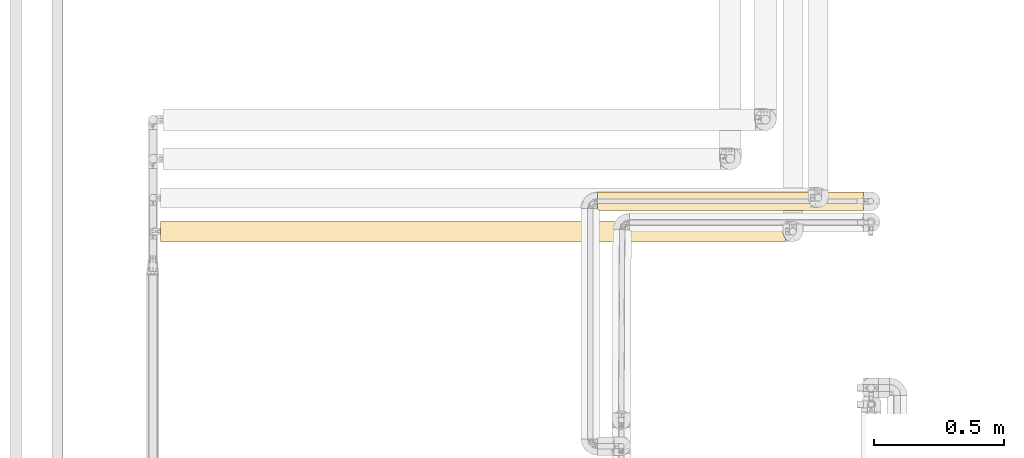
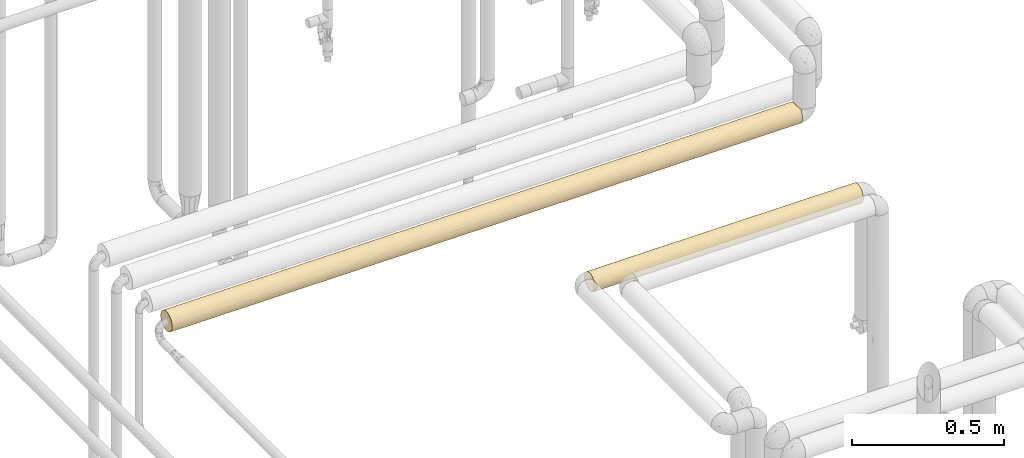
# One storey, part 32 of 827: 2 coverings.
"""IFC2X3 building model written with IfcOpenShell, lengths in millimetres."""

from ifc_helpers import new_model, entity, si_unit, converted_unit, derived_unit, direction, frame, origin, place, context, subcontext, project, spatial, faceted_brep, element, save


model = new_model("IFC2X3")

# Units and contexts
model_context = context("Model", 3, precision=0.01, world=origin(), true_north=direction((6.12303176911189e-17, 1.0)))
body_context = subcontext(model_context, "Body", "Model", "MODEL_VIEW")
ifc_project = project(units=[si_unit("LENGTHUNIT", "METRE", prefix="MILLI"), si_unit("AREAUNIT", "SQUARE_METRE"), si_unit("VOLUMEUNIT", "CUBIC_METRE"), converted_unit("PLANEANGLEUNIT", "DEGREE", entity("IfcRatioMeasure", 0.0174532925199433), si_unit("PLANEANGLEUNIT", "RADIAN"), dimensions=[0, 0, 0, 0, 0, 0, 0]), si_unit("MASSUNIT", "GRAM", prefix="KILO"), derived_unit("MASSDENSITYUNIT", [(si_unit("MASSUNIT", "GRAM", prefix="KILO"), 1), (si_unit("LENGTHUNIT", "METRE"), -3)]), derived_unit("MOMENTOFINERTIAUNIT", [(si_unit("LENGTHUNIT", "METRE"), 4)]), si_unit("TIMEUNIT", "SECOND"), si_unit("FREQUENCYUNIT", "HERTZ"), si_unit("THERMODYNAMICTEMPERATUREUNIT", "DEGREE_CELSIUS"), derived_unit("THERMALTRANSMITTANCEUNIT", [(si_unit("MASSUNIT", "GRAM", prefix="KILO"), 1), (si_unit("THERMODYNAMICTEMPERATUREUNIT", "KELVIN"), -1), (si_unit("TIMEUNIT", "SECOND"), -3)]), derived_unit("VOLUMETRICFLOWRATEUNIT", [(si_unit("LENGTHUNIT", "METRE"), 3), (si_unit("TIMEUNIT", "SECOND"), -1)]), derived_unit("MASSFLOWRATEUNIT", [(si_unit("MASSUNIT", "GRAM", prefix="KILO"), 1), (si_unit("TIMEUNIT", "SECOND"), -1)]), derived_unit("ROTATIONALFREQUENCYUNIT", [(si_unit("TIMEUNIT", "SECOND"), -1)]), si_unit("ELECTRICCURRENTUNIT", "AMPERE"), si_unit("ELECTRICVOLTAGEUNIT", "VOLT"), si_unit("POWERUNIT", "WATT"), si_unit("FORCEUNIT", "NEWTON", prefix="KILO"), si_unit("ILLUMINANCEUNIT", "LUX"), si_unit("LUMINOUSFLUXUNIT", "LUMEN"), si_unit("LUMINOUSINTENSITYUNIT", "CANDELA"), derived_unit("USERDEFINED", [(si_unit("MASSUNIT", "GRAM", prefix="KILO"), -1), (si_unit("LENGTHUNIT", "METRE"), -2), (si_unit("TIMEUNIT", "SECOND"), 3), (si_unit("LUMINOUSFLUXUNIT", "LUMEN"), 1)]), derived_unit("LINEARVELOCITYUNIT", [(si_unit("LENGTHUNIT", "METRE"), 1), (si_unit("TIMEUNIT", "SECOND"), -1)]), si_unit("PRESSUREUNIT", "PASCAL"), derived_unit("USERDEFINED", [(si_unit("LENGTHUNIT", "METRE"), -2), (si_unit("MASSUNIT", "GRAM", prefix="KILO"), 1), (si_unit("TIMEUNIT", "SECOND"), -2)]), derived_unit("LINEARFORCEUNIT", [(si_unit("MASSUNIT", "GRAM", prefix="KILO"), 1), (si_unit("LENGTHUNIT", "METRE"), 1), (si_unit("TIMEUNIT", "SECOND"), -2), (si_unit("LENGTHUNIT", "METRE"), -1)]), derived_unit("PLANARFORCEUNIT", [(si_unit("MASSUNIT", "GRAM", prefix="KILO"), 1), (si_unit("LENGTHUNIT", "METRE"), 1), (si_unit("TIMEUNIT", "SECOND"), -2), (si_unit("LENGTHUNIT", "METRE"), -2)])], contexts=[model_context])

# Site, building, storey
site_placement = place(None, origin())
site = spatial("IfcSite", under=ifc_project, at=site_placement, CompositionType="ELEMENT")
building_placement = place(site_placement, origin())
building = spatial("IfcBuilding", under=site, at=building_placement, CompositionType="ELEMENT")
storey_placement = place(building_placement, frame((0.0, 0.0, 28200.0)))
storey = spatial("IfcBuildingStorey", under=building, at=storey_placement, Name="08", CompositionType="ELEMENT", Elevation=28200.0)

# Coverings
covering_1_placement = place(storey_placement, frame((17833.66, 12899.2, 1862.75)))
element("IfcCovering", 1, at=covering_1_placement, inside=storey, Name=":ADSK_", ObjectType=":ADSK_", PredefinedType="INSULATION", context=body_context, shape_type="Brep", body=[
    faceted_brep([(1022.92, 69.32, 21.68), (1022.92, 71.99, 29.26), (1022.92, 72.9, 37.25), (1022.92, 71.68, 46.47), (1022.92, 68.12, 55.07), (1022.92, 62.45, 62.45), (1022.92, 55.07, 68.12), (1022.92, 46.47, 71.68), (1022.92, 37.25, 72.9), (1022.92, 28.02, 71.68), (1022.92, 19.42, 68.12), (1022.92, 12.04, 62.45), (1022.92, 6.37, 55.07), (1022.92, 2.81, 46.47), (1022.92, 1.6, 37.25), (1022.92, 2.5, 29.26), (1022.92, 5.17, 21.68), (1022.92, 9.47, 14.89), (1022.92, 15.18, 9.25), (1022.92, 59.31, 9.25), (1022.92, 65.02, 14.89), (1.6, 71.68, 28.02), (1.6, 68.12, 19.42), (1.6, 62.45, 12.04), (1.6, 55.07, 6.37), (1.6, 46.47, 2.81), (1.6, 37.25, 1.6), (1.6, 29.11, 2.54), (1.6, 21.41, 5.3), (1.6, 14.55, 9.75), (1.6, 8.88, 15.65), (1.6, 8.88, 58.84), (1.6, 14.55, 64.74), (1.6, 21.41, 69.19), (1.6, 29.11, 71.95), (1.6, 37.25, 72.9), (1.6, 46.47, 71.68), (1.6, 55.07, 68.12), (1.6, 62.45, 62.45), (1.6, 68.12, 55.07), (1.6, 71.68, 46.47), (1.6, 72.9, 37.25), (236.62, 7.3, 17.9), (7.01, 3.47, 25.85), (4.72, 5.76, 20.53), (1017.24, 25.57, 3.56), (1019.64, 20.14, 5.97), (740.67, 22.68, 4.71), (702.55, 30.17, 2.31), (241.25, 2.67, 28.57), (299.95, 37.25, 1.6), (306.19, 25.18, 3.7), (421.06, 4.58, 22.96), (425.84, 1.6, 37.25), (262.39, 1.6, 37.25), (217.36, 1.6, 37.25), (8.41, 2.07, 31.47), (206.28, 19.1, 6.56), (515.9, 2.36, 29.91), (605.96, 1.6, 37.25), (515.9, 1.6, 37.25), (278.89, 13.35, 10.79), (806.79, 37.25, 1.6), (1015.27, 37.25, 1.6), (1015.76, 31.32, 2.09), (476.36, 8.92, 15.59), (510.26, 17.31, 7.69), (627.19, 4.13, 24.05), (732.02, 2.27, 30.34), (668.76, 12.35, 11.73), (694.98, 17.26, 7.73), (210.08, 37.25, 1.6), (471.76, 30.57, 2.22), (418.56, 37.25, 1.6), (598.31, 37.25, 1.6), (712.79, 7.13, 18.17), (8.88, 1.6, 37.25), (814.44, 1.6, 37.25), (827.46, 4.45, 23.26), (511.37, 23.72, 4.26), (769.41, 1.6, 37.25), (281.01, 50.89, 4.31), (244.66, 65.53, 15.54), (234.73, 58.95, 8.96), (507.62, 48.48, 3.41), (605.96, 72.9, 37.25), (454.87, 72.24, 30.42), (303.78, 72.9, 37.25), (519.48, 70.32, 23.93), (314.14, 70.18, 23.6), (735.66, 46.16, 2.73), (1017.24, 48.92, 3.56), (1015.76, 43.17, 2.09), (314.32, 43.79, 2.2), (1019.64, 54.35, 5.97), (774.14, 57.04, 7.59), (604.89, 67.36, 18.17), (710.2, 71.48, 27.31), (717.44, 63.02, 12.61), (814.44, 72.9, 37.25), (242.48, 72.2, 30.23), (512.56, 57.18, 7.69), (489.28, 63.18, 12.78), (829.99, 67.36, 18.17), (418.88, 66.92, 17.49), (239.22, 65.53, 58.95), (310.05, 70.18, 50.89), (786.74, 65.53, 58.95), (528.86, 60.19, 64.53), (601.05, 50.89, 70.18), (747.68, 58.95, 65.53), (714.47, 70.18, 50.89), (512.26, 65.53, 58.95), (251.19, 72.2, 44.23), (460.48, 72.2, 44.26), (710.2, 72.3, 43.74), (310.05, 58.95, 65.53), (774.98, 45.35, 71.96), (314.32, 43.95, 72.26), (418.56, 37.25, 72.9), (537.76, 43.77, 72.29), (512.26, 70.24, 50.75), (817.43, 52.48, 69.48), (210.08, 37.25, 72.9), (243.76, 50.89, 70.18), (720.74, 37.25, 72.9), (195.62, 17.85, 67.16), (261.88, 25.18, 70.79), (749.04, 4.31, 50.89), (535.86, 4.03, 50.19), (642.65, 2.24, 44.0), (569.65, 30.44, 72.24), (498.79, 23.87, 70.29), (708.65, 23.6, 70.18), (309.19, 12.29, 62.7), (250.27, 7.31, 56.6), (318.06, 2.67, 45.95), (779.47, 15.54, 65.53), (782.44, 30.22, 72.2), (422.77, 17.85, 67.16), (841.75, 2.18, 43.66), (4.72, 5.76, 53.96), (789.77, 8.96, 58.95), (7.01, 3.47, 48.64), (8.41, 2.07, 43.02), (511.14, 7.4, 56.74), (540.26, 12.46, 62.87)], [[[0, 1, 2, 3, 4, 5, 6, 7, 8, 9, 10, 11, 12, 13, 14, 15, 16, 17, 18, 19, 20]], [[21, 22, 23, 24, 25, 26, 27, 28, 29, 30, 31, 32, 33, 34, 35, 36, 37, 38, 39, 40, 41]], [[42, 43, 44]], [[45, 46, 47]], [[48, 45, 47]], [[43, 42, 49]], [[27, 50, 51]], [[42, 52, 49]], [[49, 53, 54, 55]], [[49, 56, 43]], [[51, 57, 28]], [[58, 59, 60, 53]], [[61, 30, 29]], [[42, 44, 30]], [[53, 49, 58]], [[62, 63, 64]], [[65, 61, 66]], [[58, 67, 68]], [[18, 69, 70]], [[27, 26, 71, 50]], [[72, 50, 73, 74]], [[65, 52, 42]], [[75, 65, 69]], [[64, 45, 48]], [[75, 17, 16]], [[69, 17, 75]], [[55, 76, 56]], [[67, 52, 65]], [[61, 57, 66]], [[28, 27, 51]], [[18, 70, 46]], [[49, 52, 58]], [[55, 56, 49]], [[15, 14, 77]], [[74, 48, 72]], [[65, 75, 67]], [[58, 68, 59]], [[74, 62, 48]], [[78, 15, 68]], [[64, 48, 62]], [[72, 79, 51]], [[58, 52, 67]], [[61, 65, 42]], [[69, 65, 66]], [[30, 61, 42]], [[29, 28, 57]], [[66, 51, 79]], [[79, 48, 47]], [[50, 72, 51]], [[70, 69, 66]], [[17, 69, 18]], [[78, 75, 16]], [[68, 77, 80, 59]], [[78, 67, 75]], [[15, 77, 68]], [[15, 78, 16]], [[68, 67, 78]], [[48, 79, 72]], [[70, 79, 47]], [[66, 57, 51]], [[29, 57, 61]], [[79, 70, 66]], [[70, 47, 46]], [[81, 25, 24]], [[82, 83, 23]], [[73, 84, 74]], [[85, 86, 87]], [[88, 89, 86]], [[90, 91, 92]], [[93, 25, 81]], [[23, 83, 24]], [[19, 94, 95]], [[91, 90, 95]], [[92, 62, 90]], [[96, 88, 97]], [[19, 95, 98]], [[82, 22, 89]], [[99, 97, 85]], [[41, 87, 100]], [[101, 102, 98]], [[0, 103, 97]], [[83, 101, 81]], [[99, 2, 1]], [[22, 21, 89]], [[84, 95, 90]], [[103, 0, 20]], [[22, 82, 23]], [[73, 93, 84]], [[95, 94, 91]], [[103, 98, 96]], [[0, 97, 1]], [[99, 1, 97]], [[101, 95, 84]], [[25, 71, 26]], [[96, 102, 104]], [[102, 96, 98]], [[87, 86, 100]], [[83, 82, 102]], [[81, 24, 83]], [[20, 19, 98]], [[97, 103, 96]], [[20, 98, 103]], [[101, 98, 95]], [[83, 102, 101]], [[104, 102, 82]], [[25, 93, 71]], [[93, 73, 50, 71]], [[84, 93, 81]], [[101, 84, 81]], [[74, 84, 90]], [[97, 86, 85]], [[100, 86, 89]], [[89, 21, 100]], [[41, 100, 21]], [[97, 88, 86]], [[104, 88, 96]], [[82, 89, 104]], [[88, 104, 89]], [[62, 92, 63]], [[62, 74, 90]], [[105, 106, 39]], [[107, 5, 4]], [[108, 109, 110]], [[107, 111, 112]], [[106, 105, 112]], [[39, 106, 40]], [[87, 113, 114]], [[38, 105, 39]], [[85, 115, 99]], [[5, 107, 110]], [[4, 3, 111]], [[37, 116, 38]], [[7, 117, 8]], [[118, 119, 120]], [[111, 121, 112]], [[114, 113, 106]], [[122, 109, 117]], [[109, 122, 110]], [[110, 6, 5]], [[112, 105, 116]], [[119, 118, 123]], [[120, 117, 109]], [[124, 116, 37]], [[3, 99, 115]], [[115, 114, 121]], [[124, 37, 36]], [[118, 120, 109]], [[116, 108, 112]], [[123, 118, 36]], [[40, 113, 41]], [[109, 116, 124]], [[116, 105, 38]], [[111, 107, 4]], [[108, 107, 112]], [[3, 2, 99]], [[114, 115, 85]], [[3, 115, 111]], [[87, 114, 85]], [[121, 114, 106]], [[36, 35, 123]], [[109, 124, 118]], [[36, 118, 124]], [[119, 125, 120]], [[117, 120, 125]], [[8, 117, 125]], [[122, 7, 6]], [[7, 122, 117]], [[110, 122, 6]], [[41, 113, 87]], [[40, 106, 113]], [[112, 121, 106]], [[115, 121, 111]], [[109, 108, 116]], [[107, 108, 110]], [[126, 127, 33]], [[128, 129, 130]], [[33, 32, 126]], [[131, 132, 133]], [[34, 123, 35]], [[134, 31, 135]], [[34, 33, 127]], [[127, 123, 34]], [[129, 135, 136]], [[136, 60, 130]], [[10, 137, 11]], [[125, 138, 8]], [[134, 139, 126]], [[128, 130, 140]], [[31, 141, 135]], [[11, 142, 12]], [[130, 60, 59, 80]], [[135, 143, 136]], [[136, 143, 144]], [[144, 54, 136]], [[10, 9, 133]], [[137, 142, 11]], [[145, 146, 134]], [[13, 12, 128]], [[135, 141, 143]], [[125, 131, 138]], [[10, 133, 137]], [[127, 139, 132]], [[128, 142, 145]], [[133, 139, 137]], [[146, 139, 134]], [[142, 137, 146]], [[119, 131, 125]], [[119, 123, 127]], [[13, 140, 14]], [[128, 12, 142]], [[32, 31, 134]], [[127, 126, 139]], [[32, 134, 126]], [[145, 134, 135]], [[142, 146, 145]], [[137, 139, 146]], [[140, 130, 80]], [[128, 145, 129]], [[135, 129, 145]], [[136, 130, 129]], [[127, 131, 119]], [[138, 131, 133]], [[140, 80, 77, 14]], [[128, 140, 13]], [[133, 9, 138]], [[8, 138, 9]], [[127, 132, 131]], [[139, 133, 132]], [[144, 76, 55, 54]], [[136, 54, 53, 60]], [[64, 63, 92, 91, 94, 19, 18, 46, 45]], [[30, 44, 43, 56, 76, 144, 143, 141, 31]]]),
])
covering_2_placement = place(storey_placement, frame((16157.15, 12780.0, 2360.0)))
element("IfcCovering", 2, at=covering_2_placement, inside=storey, Name=":ADSK_", ObjectType=":ADSK_", PredefinedType="INSULATION", context=body_context, shape_type="Brep", body=[
    faceted_brep([(0.0, 6.74, 20.8), (0.0, 2.9, 30.06), (0.0, 1.6, 40.0), (0.0, 2.9, 49.93), (0.0, 6.74, 59.2), (0.0, 12.84, 67.15), (0.0, 20.8, 73.25), (0.0, 30.06, 77.09), (0.0, 40.0, 78.4), (0.0, 49.93, 77.09), (0.0, 59.2, 73.25), (0.0, 67.15, 67.15), (0.0, 73.25, 59.2), (0.0, 77.09, 49.93), (0.0, 78.4, 40.0), (0.0, 77.09, 30.06), (0.0, 73.25, 20.8), (0.0, 67.15, 12.84), (0.0, 59.2, 6.74), (0.0, 49.93, 2.9), (0.0, 40.0, 1.6), (0.0, 30.06, 2.9), (0.0, 20.8, 6.74), (0.0, 12.84, 12.84), (2399.3, 77.51, 48.2), (2399.3, 74.9, 56.01), (2399.3, 70.68, 63.08), (2399.3, 65.05, 69.1), (2399.3, 14.94, 69.1), (2399.3, 9.31, 63.08), (2399.3, 5.09, 56.01), (2399.3, 2.48, 48.2), (2399.3, 1.6, 40.0), (2399.3, 2.9, 30.06), (2399.3, 6.74, 20.8), (2399.3, 12.84, 12.84), (2399.3, 20.8, 6.74), (2399.3, 30.06, 2.9), (2399.3, 40.0, 1.6), (2399.3, 49.93, 2.9), (2399.3, 59.2, 6.74), (2399.3, 67.15, 12.84), (2399.3, 73.25, 20.8), (2399.3, 77.09, 30.06), (2399.3, 78.4, 40.0), (216.37, 78.4, 40.0), (2182.93, 78.4, 40.0), (2154.24, 54.69, 4.52), (2075.03, 63.37, 9.53), (1777.65, 77.57, 32.07), (1966.55, 78.4, 40.0), (2074.74, 77.7, 32.71), (2140.11, 70.46, 16.62), (259.19, 70.46, 16.62), (324.27, 63.37, 9.53), (2204.65, 76.1, 26.92), (1993.98, 75.47, 25.3), (1533.81, 40.0, 1.6), (1199.65, 40.0, 1.6), (1290.33, 50.21, 2.98), (561.65, 46.88, 2.22), (432.75, 40.0, 1.6), (324.56, 47.28, 2.29), (194.65, 76.1, 26.92), (324.56, 77.7, 32.71), (1837.65, 46.88, 2.22), (1540.65, 52.25, 3.6), (1869.58, 54.69, 4.52), (1571.14, 62.54, 8.91), (245.05, 54.69, 4.52), (2182.93, 40.0, 1.6), (216.37, 40.0, 1.6), (2074.74, 47.28, 2.29), (1966.55, 40.0, 1.6), (529.72, 54.69, 4.52), (491.43, 68.23, 13.97), (1032.57, 50.31, 3.01), (892.08, 61.66, 8.29), (1265.32, 58.44, 6.32), (757.11, 75.13, 24.5), (723.66, 70.46, 16.62), (536.77, 72.71, 19.89), (1533.81, 78.4, 40.0), (1409.69, 76.2, 27.2), (1226.92, 65.14, 10.97), (1435.28, 68.69, 14.48), (1382.71, 73.02, 20.41), (1648.17, 74.99, 24.19), (1675.64, 70.46, 16.62), (432.75, 78.4, 40.0), (405.32, 75.47, 25.3), (621.65, 77.57, 32.07), (1832.18, 62.1, 8.6), (1907.87, 68.23, 13.97), (1862.53, 72.71, 19.89), (567.12, 62.1, 8.6), (1005.66, 67.4, 13.09), (1750.18, 40.0, 1.6), (649.12, 40.0, 1.6), (865.49, 40.0, 1.6), (775.95, 51.88, 3.48), (958.97, 72.53, 19.6), (1205.11, 77.57, 32.06), (1016.6, 76.35, 27.62), (1210.2, 75.11, 24.46), (1750.18, 78.4, 40.0), (649.12, 78.4, 40.0), (844.32, 77.63, 32.35), (865.49, 78.4, 40.0), (1199.65, 78.4, 40.0), (1199.65, 70.73, 16.98), (2140.11, 9.53, 16.62), (2075.03, 16.62, 9.53), (259.19, 16.62, 9.53), (491.43, 13.97, 11.76), (324.27, 9.53, 16.62), (1286.23, 22.04, 6.05), (1357.34, 12.64, 13.04), (1049.14, 15.51, 10.41), (2204.65, 3.89, 26.92), (2074.74, 2.29, 32.71), (2154.24, 25.3, 4.52), (1869.58, 25.3, 4.52), (1697.35, 2.89, 30.12), (1533.81, 1.6, 40.0), (1366.73, 3.03, 29.61), (701.95, 30.12, 2.89), (1032.57, 29.61, 3.03), (1907.87, 11.76, 13.97), (833.46, 4.31, 25.81), (1113.07, 6.05, 22.04), (1068.9, 2.61, 31.22), (324.56, 32.71, 2.29), (561.65, 2.22, 33.12), (432.75, 1.6, 40.0), (324.56, 2.29, 32.71), (529.72, 4.52, 25.3), (567.12, 8.6, 17.89), (245.05, 4.52, 25.3), (216.37, 1.6, 40.0), (2074.74, 32.71, 2.29), (1837.65, 33.12, 2.22), (194.65, 26.92, 3.89), (1300.17, 30.76, 2.72), (1642.53, 17.84, 8.63), (1554.97, 27.8, 3.58), (1966.55, 1.6, 40.0), (2182.93, 1.6, 40.0), (1750.18, 1.6, 40.0), (1675.64, 9.53, 16.62), (1858.8, 17.23, 9.07), (852.42, 9.49, 16.68), (723.66, 16.62, 9.53), (1199.65, 1.6, 40.0), (1862.53, 7.28, 19.89), (536.77, 19.89, 7.28), (1054.71, 22.19, 5.97), (405.32, 25.3, 4.52), (729.29, 23.07, 5.53), (1670.01, 5.53, 23.07), (1389.97, 6.79, 20.7), (1148.04, 10.42, 15.5), (863.36, 2.29, 32.74), (1993.98, 4.52, 25.3), (865.49, 1.6, 40.0), (649.12, 1.6, 40.0), (2182.23, 7.01, 59.66), (324.27, 16.62, 70.46), (1957.25, 40.0, 78.4), (2065.44, 31.75, 77.5), (2173.63, 40.0, 78.4), (2392.4, 26.63, 76.0), (2390.6, 33.21, 77.79), (1478.92, 23.5, 74.67), (1794.84, 22.88, 74.37), (1712.83, 29.53, 76.94), (324.56, 2.29, 47.28), (194.65, 3.89, 53.07), (2113.66, 3.58, 52.17), (2113.65, 11.96, 66.24), (561.65, 33.12, 77.77), (432.75, 40.0, 78.4), (324.56, 32.71, 77.7), (245.05, 25.3, 75.47), (529.72, 25.3, 75.47), (1784.08, 2.85, 49.74), (1617.88, 6.04, 57.93), (1447.3, 2.9, 49.91), (405.32, 4.52, 54.69), (621.65, 2.42, 47.92), (654.04, 5.17, 56.17), (1915.71, 7.01, 59.66), (972.85, 16.61, 70.45), (1195.0, 25.96, 75.74), (860.36, 27.73, 76.38), (2015.9, 23.31, 74.58), (2395.33, 20.48, 73.07), (1483.24, 10.56, 64.66), (1329.24, 16.06, 70.02), (1256.96, 10.72, 64.85), (1730.0, 10.26, 64.29), (259.19, 9.53, 63.37), (1683.7, 17.22, 70.91), (1895.92, 14.33, 68.56), (216.37, 40.0, 78.4), (2074.43, 17.32, 70.98), (1396.05, 31.87, 77.53), (723.66, 9.53, 63.37), (629.79, 16.65, 70.48), (491.43, 11.43, 65.65), (2390.0, 40.0, 78.4), (1064.04, 7.29, 60.11), (856.16, 6.32, 58.45), (981.72, 3.69, 52.51), (1740.88, 40.0, 78.4), (1524.51, 40.0, 78.4), (1056.87, 32.85, 77.73), (865.49, 40.0, 78.4), (649.12, 40.0, 78.4), (1217.32, 3.44, 51.77), (1315.44, 6.41, 58.62), (1051.35, 11.65, 65.9), (1195.0, 40.0, 78.4), (2113.65, 68.03, 66.24), (2102.66, 62.48, 71.12), (621.65, 47.92, 77.57), (734.1, 55.89, 74.95), (405.32, 54.69, 75.47), (2113.66, 76.41, 52.17), (2182.23, 72.98, 59.66), (1915.71, 72.98, 59.66), (1909.01, 64.93, 69.19), (886.46, 76.35, 52.37), (1036.17, 72.84, 59.89), (1140.0, 76.25, 52.64), (763.98, 71.4, 62.09), (2392.4, 53.36, 76.0), (2395.33, 59.51, 73.07), (2015.9, 56.68, 74.58), (245.05, 75.47, 54.69), (1506.18, 46.78, 77.79), (1460.0, 53.21, 76.05), (1308.95, 47.14, 77.73), (324.56, 47.28, 77.7), (194.65, 53.07, 76.1), (1097.71, 46.5, 77.84), (324.27, 70.46, 63.37), (1784.08, 77.14, 49.74), (1617.88, 73.95, 57.93), (259.19, 63.37, 70.46), (529.72, 75.47, 54.69), (561.65, 77.77, 46.88), (324.56, 77.7, 47.28), (2390.6, 46.78, 77.79), (2065.44, 48.24, 77.5), (1485.97, 68.6, 65.62), (1742.23, 69.13, 65.01), (1712.83, 50.46, 76.94), (491.43, 66.03, 68.23), (723.66, 63.37, 70.46), (543.91, 70.98, 62.68), (1097.38, 66.67, 67.62), (1275.54, 69.46, 64.62), (1794.84, 57.11, 74.37), (1683.7, 62.77, 70.91), (1388.15, 61.13, 72.05), (963.9, 59.09, 73.31), (916.07, 50.21, 77.01), (1579.11, 77.69, 47.32), (1366.73, 77.36, 48.85), (536.77, 60.1, 72.71), (1315.44, 73.58, 58.62), (1195.0, 54.03, 75.74), (1173.1, 60.65, 72.37)], [[[0, 1, 2, 3, 4, 5, 6, 7, 8, 9, 10, 11, 12, 13, 14, 15, 16, 17, 18, 19, 20, 21, 22, 23]], [[24, 25, 26, 27, 28, 29, 30, 31, 32, 33, 34, 35, 36, 37, 38, 39, 40, 41, 42, 43, 44]], [[15, 14, 45]], [[46, 44, 43]], [[40, 47, 48]], [[49, 50, 51]], [[42, 41, 52]], [[17, 53, 54]], [[51, 55, 56]], [[57, 58, 59]], [[60, 61, 62]], [[63, 15, 64]], [[65, 66, 67]], [[47, 40, 39]], [[66, 68, 67]], [[69, 19, 18]], [[39, 38, 70]], [[19, 71, 20]], [[61, 71, 62]], [[72, 70, 73]], [[69, 54, 74]], [[48, 47, 67]], [[53, 75, 54]], [[47, 72, 67]], [[74, 62, 69]], [[76, 77, 78]], [[79, 80, 81]], [[82, 49, 83]], [[54, 18, 17]], [[52, 41, 48]], [[68, 84, 85]], [[43, 55, 51]], [[40, 48, 41]], [[86, 87, 88]], [[43, 51, 46]], [[64, 45, 89]], [[90, 64, 91]], [[48, 92, 93]], [[67, 72, 65]], [[94, 52, 93]], [[17, 16, 53]], [[95, 74, 54]], [[78, 66, 59]], [[96, 84, 77]], [[93, 52, 48]], [[55, 52, 56]], [[63, 53, 16]], [[75, 81, 80]], [[70, 72, 39]], [[54, 69, 18]], [[62, 19, 69]], [[72, 73, 65]], [[39, 72, 47]], [[65, 73, 97, 57]], [[98, 61, 60]], [[66, 78, 68]], [[65, 57, 66]], [[99, 76, 58]], [[76, 78, 59]], [[46, 51, 50]], [[75, 95, 54]], [[77, 76, 100]], [[101, 96, 80]], [[82, 83, 102]], [[103, 102, 104]], [[68, 78, 84]], [[93, 92, 88]], [[74, 60, 62]], [[19, 62, 71]], [[100, 60, 74]], [[100, 98, 60]], [[100, 74, 95]], [[99, 100, 76]], [[98, 100, 99]], [[49, 51, 56]], [[56, 94, 87]], [[49, 82, 105, 50]], [[87, 94, 88]], [[86, 104, 83]], [[80, 79, 101]], [[90, 79, 81]], [[43, 42, 55]], [[52, 55, 42]], [[91, 64, 89]], [[45, 64, 15]], [[64, 90, 63]], [[91, 89, 106]], [[91, 106, 107]], [[53, 63, 90]], [[16, 15, 63]], [[108, 109, 82, 102]], [[48, 67, 92]], [[94, 93, 88]], [[67, 68, 92]], [[88, 92, 68]], [[86, 88, 85]], [[52, 94, 56]], [[83, 49, 87]], [[56, 87, 49]], [[81, 53, 90]], [[95, 80, 77]], [[80, 95, 75]], [[100, 95, 77]], [[53, 81, 75]], [[79, 90, 91]], [[107, 79, 91]], [[103, 104, 101]], [[103, 101, 79]], [[96, 101, 110]], [[84, 96, 110]], [[80, 96, 77]], [[84, 110, 85]], [[77, 84, 78]], [[86, 85, 110]], [[68, 85, 88]], [[110, 101, 104]], [[87, 86, 83]], [[110, 104, 86]], [[107, 102, 103]], [[83, 104, 102]], [[57, 59, 66]], [[58, 76, 59]], [[102, 107, 108]], [[107, 106, 108]], [[79, 107, 103]], [[35, 111, 112]], [[113, 114, 115]], [[116, 117, 118]], [[119, 33, 120]], [[121, 37, 36]], [[112, 122, 121]], [[123, 124, 125]], [[126, 99, 127]], [[111, 128, 112]], [[113, 115, 23]], [[129, 130, 131]], [[61, 132, 71]], [[133, 134, 135]], [[112, 36, 35]], [[129, 136, 137]], [[136, 138, 115]], [[134, 139, 135]], [[21, 71, 132]], [[140, 73, 70]], [[141, 73, 140]], [[142, 21, 132]], [[138, 1, 0]], [[127, 143, 116]], [[117, 116, 144]], [[115, 0, 23]], [[145, 141, 122]], [[146, 120, 147]], [[126, 61, 98, 99]], [[33, 147, 120]], [[123, 146, 148, 124]], [[35, 34, 111]], [[37, 70, 38]], [[21, 20, 71]], [[149, 150, 128]], [[23, 22, 113]], [[1, 139, 2]], [[33, 32, 147]], [[137, 136, 115]], [[145, 144, 116]], [[128, 150, 112]], [[118, 151, 152]], [[153, 125, 124]], [[119, 111, 34]], [[128, 154, 149]], [[142, 113, 22]], [[114, 155, 152]], [[112, 121, 36]], [[140, 37, 121]], [[115, 138, 0]], [[135, 1, 138]], [[122, 141, 140]], [[37, 140, 70]], [[122, 140, 121]], [[122, 144, 145]], [[141, 57, 97, 73]], [[145, 116, 143]], [[57, 141, 145]], [[58, 127, 99]], [[145, 143, 57]], [[144, 149, 117]], [[118, 156, 116]], [[157, 158, 155]], [[149, 159, 160]], [[151, 118, 161]], [[155, 158, 152]], [[126, 157, 132]], [[161, 118, 117]], [[152, 158, 156]], [[129, 151, 130]], [[137, 115, 114]], [[153, 131, 125]], [[129, 162, 133]], [[130, 161, 160]], [[129, 131, 162]], [[163, 159, 154]], [[154, 159, 149]], [[123, 163, 120]], [[125, 131, 130]], [[164, 131, 153]], [[136, 133, 135]], [[1, 135, 139]], [[136, 135, 138]], [[129, 133, 136]], [[162, 165, 133]], [[165, 134, 133]], [[160, 161, 117]], [[132, 157, 142]], [[113, 142, 157]], [[22, 21, 142]], [[131, 164, 162]], [[120, 163, 119]], [[111, 119, 163]], [[34, 33, 119]], [[154, 111, 163]], [[150, 149, 144]], [[111, 154, 128]], [[159, 163, 123]], [[123, 125, 159]], [[160, 125, 130]], [[144, 122, 150]], [[122, 112, 150]], [[155, 113, 157]], [[137, 152, 151]], [[152, 137, 114]], [[129, 137, 151]], [[113, 155, 114]], [[158, 157, 126]], [[126, 127, 158]], [[158, 127, 156]], [[127, 58, 143]], [[57, 143, 58]], [[149, 160, 117]], [[159, 125, 160]], [[61, 126, 132]], [[151, 161, 130]], [[156, 118, 152]], [[127, 116, 156]], [[146, 123, 120]], [[162, 164, 165]], [[166, 30, 29]], [[167, 6, 5]], [[168, 169, 170]], [[171, 172, 169]], [[173, 174, 175]], [[176, 177, 3]], [[178, 147, 31]], [[29, 179, 166]], [[180, 181, 182]], [[183, 167, 184]], [[185, 186, 187]], [[188, 189, 190]], [[166, 191, 178]], [[192, 193, 194]], [[170, 169, 172]], [[169, 175, 195]], [[196, 171, 195]], [[197, 198, 199]], [[200, 186, 191]], [[167, 5, 201]], [[202, 200, 203]], [[3, 139, 176]], [[28, 179, 29]], [[181, 204, 182]], [[183, 7, 6]], [[173, 193, 198]], [[178, 185, 146]], [[195, 174, 205]], [[30, 178, 31]], [[193, 173, 206]], [[207, 208, 209]], [[134, 176, 139]], [[188, 176, 189]], [[205, 28, 196]], [[174, 203, 205]], [[185, 178, 191]], [[31, 147, 32]], [[5, 4, 201]], [[7, 204, 8]], [[201, 209, 167]], [[172, 210, 170]], [[198, 193, 192]], [[211, 212, 213]], [[175, 168, 214, 215]], [[169, 195, 171]], [[194, 216, 217]], [[174, 195, 175]], [[194, 217, 180]], [[208, 194, 184]], [[186, 185, 191]], [[185, 124, 148, 146]], [[177, 201, 4]], [[146, 147, 178]], [[188, 190, 209]], [[167, 183, 6]], [[182, 7, 183]], [[184, 180, 182]], [[7, 182, 204]], [[184, 182, 183]], [[194, 180, 184]], [[180, 217, 218, 181]], [[184, 167, 208]], [[194, 193, 216]], [[213, 219, 211]], [[198, 202, 173]], [[220, 197, 199]], [[197, 220, 186]], [[3, 2, 139]], [[189, 176, 134]], [[176, 188, 177]], [[189, 134, 165, 164]], [[189, 164, 213]], [[153, 187, 219]], [[220, 199, 211]], [[201, 177, 188]], [[4, 3, 177]], [[186, 200, 197]], [[187, 186, 220]], [[219, 187, 220]], [[211, 219, 220]], [[153, 213, 164]], [[153, 124, 187]], [[202, 198, 197]], [[203, 191, 179]], [[202, 197, 200]], [[207, 192, 208]], [[194, 208, 192]], [[213, 190, 189]], [[209, 190, 207]], [[192, 221, 198]], [[207, 212, 221]], [[221, 211, 199]], [[190, 212, 207]], [[213, 212, 190]], [[221, 212, 211]], [[191, 203, 200]], [[203, 179, 205]], [[28, 205, 179]], [[196, 195, 205]], [[174, 173, 202]], [[222, 216, 206]], [[206, 175, 215]], [[175, 206, 173]], [[222, 206, 215]], [[198, 221, 199]], [[207, 221, 192]], [[167, 209, 208]], [[188, 209, 201]], [[191, 166, 179]], [[30, 166, 178]], [[168, 175, 169]], [[203, 174, 202]], [[124, 185, 187]], [[153, 219, 213]], [[206, 216, 193]], [[217, 216, 222]], [[27, 223, 224]], [[225, 226, 227]], [[228, 229, 25]], [[223, 230, 231]], [[26, 223, 27]], [[229, 230, 223]], [[232, 233, 234]], [[235, 233, 232]], [[236, 237, 238]], [[239, 13, 12]], [[240, 241, 242]], [[243, 244, 9]], [[222, 245, 217]], [[246, 12, 11]], [[247, 248, 230]], [[214, 240, 215]], [[11, 249, 246]], [[228, 25, 24]], [[230, 228, 247]], [[239, 246, 250]], [[251, 89, 252]], [[253, 236, 254]], [[255, 256, 248]], [[9, 204, 243]], [[89, 45, 252]], [[108, 251, 232]], [[50, 228, 46]], [[223, 26, 229]], [[170, 210, 253]], [[168, 254, 257]], [[249, 258, 246]], [[181, 243, 204]], [[227, 243, 225]], [[230, 256, 231]], [[223, 231, 224]], [[228, 24, 46]], [[247, 228, 50]], [[11, 10, 249]], [[13, 45, 14]], [[259, 260, 258]], [[254, 236, 238]], [[168, 170, 254]], [[261, 262, 233]], [[253, 254, 170]], [[254, 238, 257]], [[238, 263, 257]], [[264, 256, 255]], [[241, 264, 265]], [[266, 226, 267]], [[247, 50, 105]], [[268, 82, 269]], [[24, 44, 46]], [[244, 249, 10]], [[258, 270, 259]], [[246, 239, 12]], [[252, 13, 239]], [[250, 251, 252]], [[13, 252, 45]], [[250, 252, 239]], [[232, 251, 250]], [[251, 108, 106, 89]], [[235, 232, 250]], [[258, 260, 246]], [[109, 269, 82]], [[108, 232, 234]], [[235, 259, 261]], [[266, 259, 226]], [[255, 265, 264]], [[109, 108, 234]], [[269, 271, 248]], [[9, 8, 204]], [[225, 243, 181]], [[243, 227, 244]], [[225, 181, 218, 217]], [[225, 217, 267]], [[249, 244, 227]], [[10, 9, 244]], [[248, 247, 268]], [[248, 271, 255]], [[271, 262, 255]], [[266, 272, 273]], [[265, 255, 262]], [[241, 265, 272]], [[222, 242, 245]], [[267, 272, 266]], [[273, 272, 265]], [[215, 240, 242]], [[261, 259, 266]], [[226, 259, 270]], [[225, 267, 226]], [[241, 272, 242]], [[241, 257, 263]], [[245, 272, 267]], [[215, 242, 222]], [[272, 245, 242]], [[217, 245, 267]], [[256, 264, 231]], [[248, 256, 230]], [[263, 231, 264]], [[224, 231, 238]], [[238, 237, 224]], [[27, 224, 237]], [[270, 249, 227]], [[260, 259, 235]], [[235, 250, 260]], [[250, 246, 260]], [[249, 270, 258]], [[226, 270, 227]], [[261, 233, 235]], [[234, 271, 269]], [[271, 234, 233]], [[109, 234, 269]], [[214, 168, 257]], [[257, 241, 240]], [[25, 229, 26]], [[230, 229, 228]], [[240, 214, 257]], [[231, 263, 238]], [[241, 263, 264]], [[248, 268, 269]], [[268, 105, 82]], [[105, 268, 247]], [[233, 262, 271]], [[262, 261, 273]], [[262, 273, 265]], [[261, 266, 273]], [[172, 171, 196, 28, 27, 237, 236, 253, 210]]]),
])

save(model, "model.ifc")
